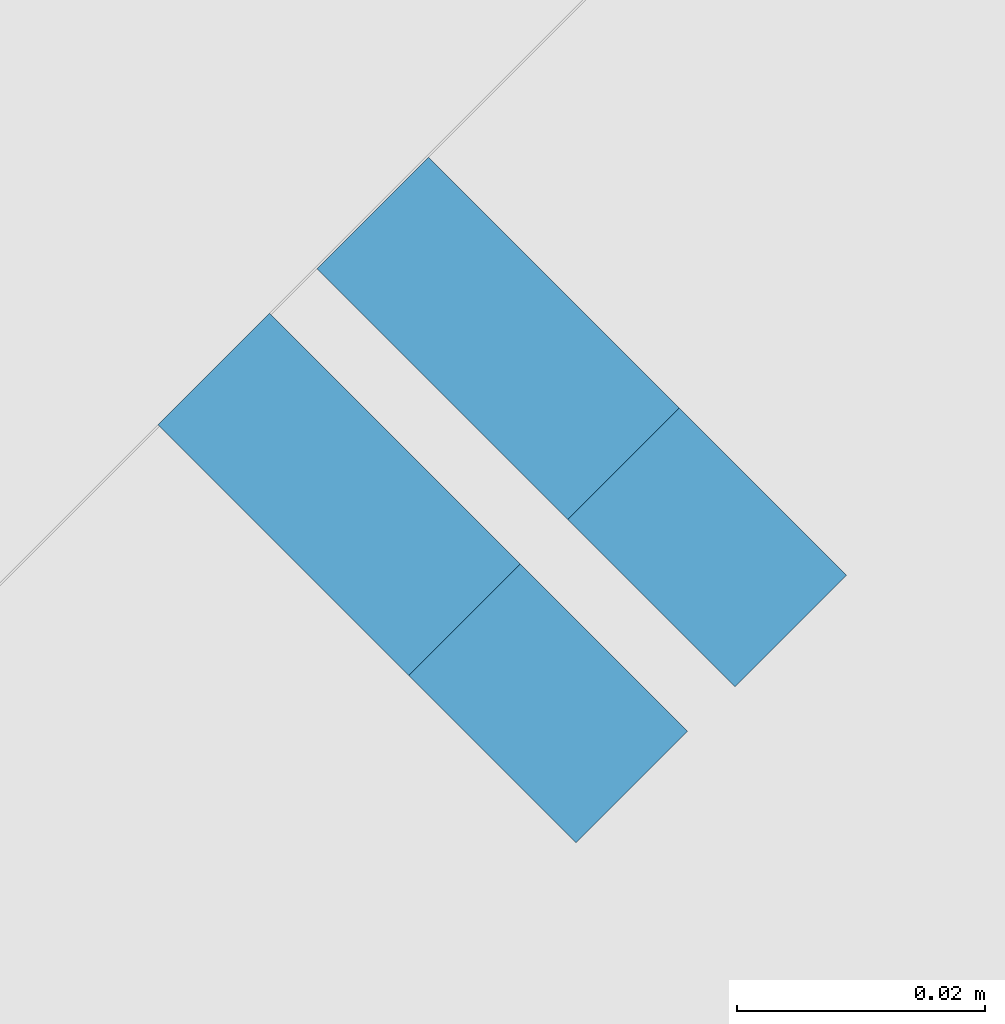
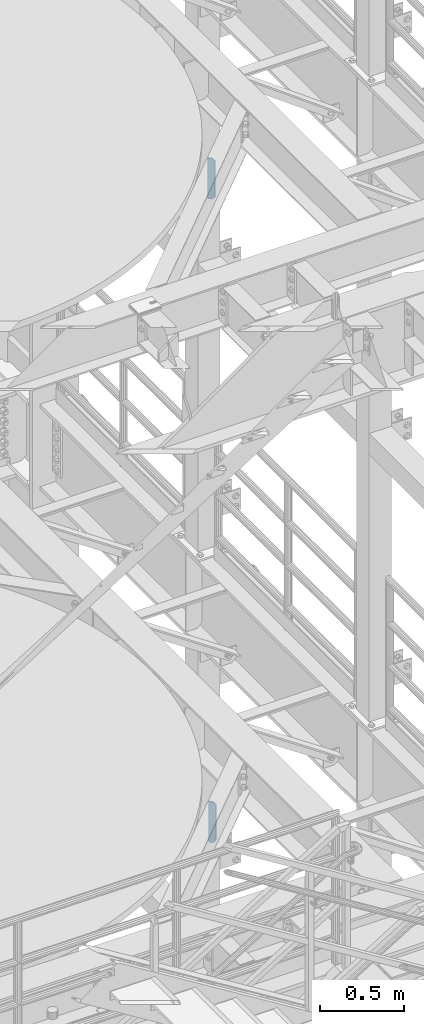
# One storey, part 1514 of 1876: 2 plates, 2 elements without a shape of their own.
"""IFC2X3 building model written with IfcOpenShell, lengths in millimetres."""

from ifc_helpers import new_model, si_unit, frame, origin_with_axes, place, context, subcontext, project, spatial, faceted_brep, material, type_object, element, aggregate, save


model = new_model("IFC2X3")

# Units and contexts
model_context = context("Model", 3, precision=1e-05, world=origin_with_axes())
body_context = subcontext(model_context, "Body", "Model", "MODEL_VIEW")
ifc_project = project(units=[si_unit("LENGTHUNIT", "METRE", prefix="MILLI"), si_unit("AREAUNIT", "SQUARE_METRE"), si_unit("VOLUMEUNIT", "CUBIC_METRE"), si_unit("MASSUNIT", "GRAM", prefix="KILO"), si_unit("TIMEUNIT", "SECOND"), si_unit("PLANEANGLEUNIT", "RADIAN"), si_unit("SOLIDANGLEUNIT", "STERADIAN"), si_unit("THERMODYNAMICTEMPERATUREUNIT", "DEGREE_CELSIUS"), si_unit("LUMINOUSINTENSITYUNIT", "LUMEN")], contexts=[model_context])

# Site, building, storey
site_placement = place(None, origin_with_axes())
site = spatial("IfcSite", under=ifc_project, at=site_placement, CompositionType="ELEMENT")
building_placement = place(site_placement, origin_with_axes())
building = spatial("IfcBuilding", under=site, at=building_placement, Name="Undefined", CompositionType="ELEMENT")
storey_placement = place(building_placement, origin_with_axes())
storey = spatial("IfcBuildingStorey", under=building, at=storey_placement, Name="Undefined", CompositionType="ELEMENT", Elevation=0.0)

# Assembly, plate
assembly_1_placement = place(storey_placement, origin_with_axes())
assembly_1 = element("IfcElementAssembly", 1, at=assembly_1_placement, inside=storey, Name="BEAM", AssemblyPlace="NOTDEFINED", PredefinedType="RIGID_FRAME")
ifc_material = material(Name="STEEL/A36")
plate_type = type_object("IfcPlateType", PredefinedType="NOTDEFINED")
plate_1_placement = place(assembly_1_placement, frame((6342.89400946493, -2872.55778569044, 17684.75), z_axis=(0.0, 0.0, 1.0), x_axis=(-0.707106781186548, 0.707106781186547, 0.0)))
plate_1 = element("IfcPlate", 2, at=plate_1_placement, type_object=plate_type, material=ifc_material, Name="PLATE", context=body_context, shape_type="Brep", body=[
    faceted_brep([(0.0, -6.35000000000196, 19.0499992370605), (9.09494701772928e-13, -6.34999999999832, 273.050006866455), (-2.72848410531878e-12, 6.34999999999923, 273.050006866455), (0.0, 6.35000000000105, 19.0499992370605), (19.0499992370578, -6.35000000000696, 292.100006103516), (19.049999237056, 6.3499999999915, 292.100006103516), (47.6249999999927, -6.3500000000206, 292.100006103516), (47.62499999999, 6.34999999997831, 292.100006103516), (47.6249999999927, -6.3500000000206, 3.63797880709171e-12), (47.62499999999, 6.34999999997831, 3.63797880709171e-12), (19.0499992370642, -6.35000000000105, 0.0), (19.0499992370633, 6.35000000000105, 0.0)], [[[0, 1, 2, 3]], [[1, 4, 5, 2]], [[4, 6, 7, 5]], [[6, 8, 9, 7]], [[8, 10, 11, 9]], [[10, 0, 3, 11]], [[5, 7, 9, 11, 3, 2]], [[10, 8, 6, 4, 1, 0]]]),
])
aggregate(assembly_1, [plate_1])

assembly_2_placement = place(storey_placement, origin_with_axes())
assembly_2 = element("IfcElementAssembly", 3, at=assembly_2_placement, inside=storey, Name="BEAM", AssemblyPlace="NOTDEFINED", PredefinedType="RIGID_FRAME")
plate_2_placement = place(assembly_2_placement, frame((6355.7217738456, -2859.98558155807, 13011.15), z_axis=(0.0, 0.0, 1.0), x_axis=(-0.707106781186548, 0.707106781186547, 0.0)))
plate_2 = element("IfcPlate", 4, at=plate_2_placement, type_object=plate_type, material=ifc_material, Name="PLATE", context=body_context, shape_type="Brep", body=[
    faceted_brep([(0.0, -6.35000000000196, 19.0499992370605), (9.09494701772928e-13, -6.34999999999832, 273.050006866455), (-2.72848410531878e-12, 6.34999999999923, 273.050006866455), (0.0, 6.35000000000105, 19.0499992370605), (19.0499992370578, -6.35000000000696, 292.100006103516), (19.049999237056, 6.3499999999915, 292.100006103516), (47.6249999999927, -6.3500000000206, 292.100006103516), (47.62499999999, 6.34999999997831, 292.100006103516), (47.6249999999927, -6.3500000000206, 3.63797880709171e-12), (47.62499999999, 6.34999999997831, 3.63797880709171e-12), (19.0499992370642, -6.35000000000105, 0.0), (19.0499992370633, 6.35000000000105, 0.0)], [[[0, 1, 2, 3]], [[1, 4, 5, 2]], [[4, 6, 7, 5]], [[6, 8, 9, 7]], [[8, 10, 11, 9]], [[10, 0, 3, 11]], [[5, 7, 9, 11, 3, 2]], [[10, 8, 6, 4, 1, 0]]]),
])
aggregate(assembly_2, [plate_2])

save(model, "model.ifc")
